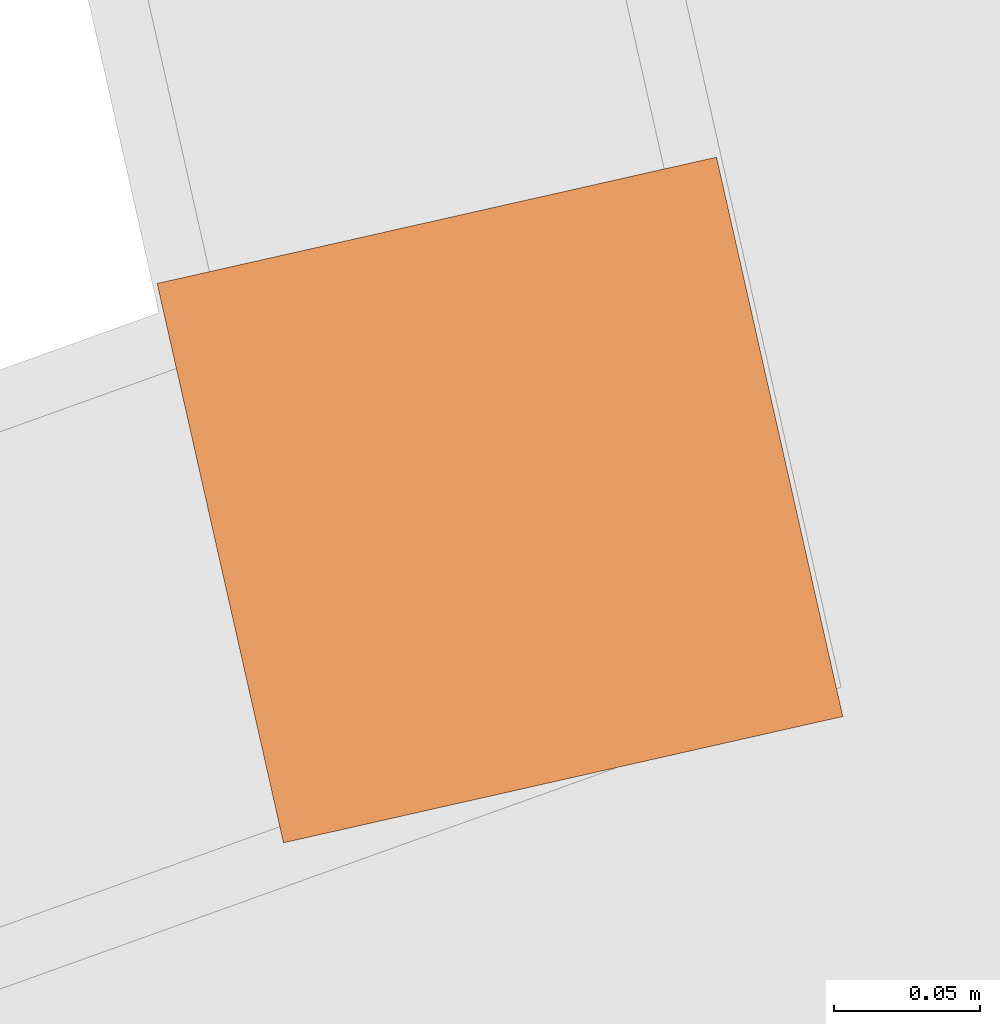
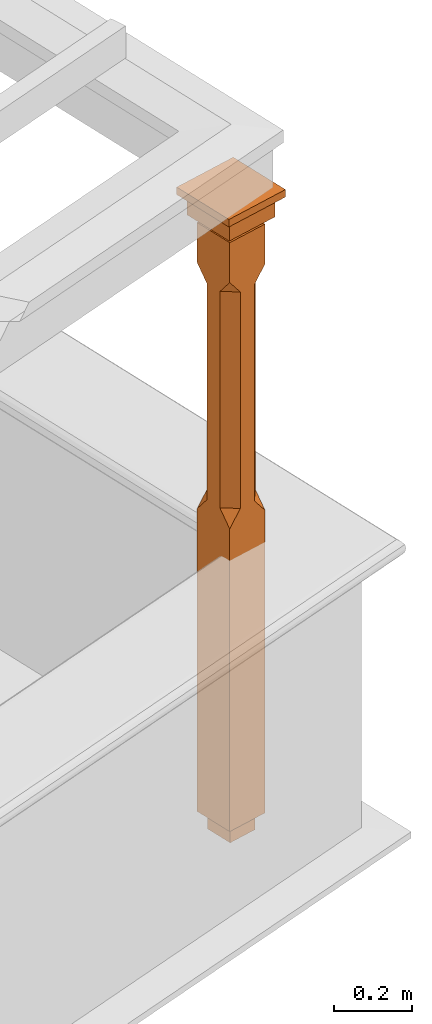
# One storey, part 10 of 10: 1 proxy.
"""IFC2X3 building model written with IfcOpenShell, lengths in metres."""

import ifcopenshell
import ifcopenshell.guid

model = None  # the IFC model being written
_history = None  # IfcOwnerHistory: only IFC2X3 demands one
_inside = {}  # id of a spatial element -> (the spatial element, [elements in it])
_under = {}  # id of a project, library or spatial element -> (it, [spatial elements below it])
_declared = {}  # id of a project -> (the project, [libraries it declares])
_typed = {}  # id of a type object -> (the type object, [elements of that type])
_made_of = {}  # id of a material, layer set ... -> (it, [elements and type objects made of it])


def new_model(schema):
    """Start an empty IFC model of exactly this schema.

    Asked for "IFC4X3", IfcOpenShell would pick the latest addendum, in which some entities
    have other attributes; the version numbers below select the first issue.
    IFC2X3 requires an IfcOwnerHistory on every rooted entity: one is made here for all.
    """
    global model, _history
    if schema == "IFC4X3":
        model = ifcopenshell.file(schema_version=(4, 3, 0, 0))
    else:
        model = ifcopenshell.file(schema=schema)
    _inside.clear()
    _under.clear()
    _declared.clear()
    _typed.clear()
    _made_of.clear()
    _history = None
    if model.schema == "IFC2X3":
        org = make("IfcOrganization", Name="unknown")
        user = make(
            "IfcPersonAndOrganization",
            ThePerson=make("IfcPerson", FamilyName="unknown"),
            TheOrganization=org,
        )
        app = make(
            "IfcApplication",
            ApplicationDeveloper=org,
            Version="unknown",
            ApplicationFullName="unknown",
            ApplicationIdentifier="unknown",
        )
        _history = make(
            "IfcOwnerHistory",
            OwningUser=user,
            OwningApplication=app,
            ChangeAction="ADDED",
            CreationDate=0,
        )
    return model


def make(cls, **values):
    """One entity of the class cls with the attributes given. An attribute that is None is left unset."""
    return model.create_entity(
        cls, **{name: value for name, value in values.items() if value is not None}
    )


def rooted(cls, **values):
    """An entity with a GlobalId (a new one), such as an element, a storey or a relation."""
    return make(cls, GlobalId=ifcopenshell.guid.new(), OwnerHistory=_history, **values)


def si_unit(unit_type, name, prefix=None):
    """IfcSIUnit, for example si_unit("LENGTHUNIT", "METRE", prefix="MILLI")."""
    return make("IfcSIUnit", UnitType=unit_type, Prefix=prefix, Name=name)


def assignment(units):
    """IfcUnitAssignment: the units of a project."""
    return None if units is None else make("IfcUnitAssignment", Units=units)


def point(xyz):
    """IfcCartesianPoint."""
    return None if xyz is None else make("IfcCartesianPoint", Coordinates=xyz)


def direction(xyz):
    """IfcDirection."""
    return None if xyz is None else make("IfcDirection", DirectionRatios=xyz)


def frame(location, z_axis=None, x_axis=None):
    """IfcAxis2Placement3D, a coordinate frame: its origin and axes. An axis left out is left unset."""
    return make(
        "IfcAxis2Placement3D",
        Location=point(location),
        Axis=direction(z_axis),
        RefDirection=direction(x_axis),
    )


def origin():
    """The frame at (0, 0, 0) with its axes left unset."""
    return frame((0.0, 0.0, 0.0))


def place(relative_to, where):
    """IfcLocalPlacement: puts the frame where relative to a parent placement (None: the world)."""
    return make(
        "IfcLocalPlacement", PlacementRelTo=relative_to, RelativePlacement=where
    )


def context(
    kind, dimensions, precision=None, world=None, true_north=None, identifier=None
):
    """IfcGeometricRepresentationContext, for example the 3D "Model" context."""
    return make(
        "IfcGeometricRepresentationContext",
        ContextIdentifier=identifier,
        ContextType=kind,
        CoordinateSpaceDimension=dimensions,
        Precision=precision,
        WorldCoordinateSystem=world,
        TrueNorth=true_north,
    )


def subcontext(parent, identifier, kind, view, scale=None):
    """IfcGeometricRepresentationSubContext, for example "Body" below "Model"."""
    return make(
        "IfcGeometricRepresentationSubContext",
        ContextIdentifier=identifier,
        ContextType=kind,
        ParentContext=parent,
        TargetScale=scale,
        TargetView=view,
    )


def project(units=None, contexts=None):
    """IfcProject with its units and contexts."""
    return rooted(
        "IfcProject",
        Name="project",
        RepresentationContexts=contexts,
        UnitsInContext=assignment(units),
    )


def spatial(cls, under=None, at=None, **own):
    """A site, building, storey or space (cls), placed at a placement, below another one or the project."""
    s = rooted(cls, ObjectPlacement=at, **own)
    if under is not None:
        _under.setdefault(under.id(), (under, []))[1].append(s)
    return s


def faces_of(points, faces, orient=None, outer=None):
    """IfcFace entities. A face is a list of loops; a loop is a list of indices into points, from 0.

    orient and outer hold one flag for each loop. By default every Orientation is true, the
    first loop of a face is its IfcFaceOuterBound and the others are IfcFaceBound.
    """
    made = []
    for i, loops in enumerate(faces):
        bounds = []
        for j, loop in enumerate(loops):
            is_outer = j == 0 if outer is None else outer[i][j]
            bounds.append(
                make(
                    "IfcFaceOuterBound" if is_outer else "IfcFaceBound",
                    Bound=make("IfcPolyLoop", Polygon=[points[k] for k in loop]),
                    Orientation=True if orient is None else orient[i][j],
                )
            )
        made.append(make("IfcFace", Bounds=bounds))
    return made


def faceted_brep(points, faces, orient=None, outer=None, voids=None):
    """IfcFacetedBrep: a solid bounded by flat faces; with voids (closed shells), ...WithVoids."""
    shared = [point(p) for p in points]
    hull = make("IfcClosedShell", CfsFaces=faces_of(shared, faces, orient, outer))
    if voids is None:
        return make("IfcFacetedBrep", Outer=hull)
    return make(
        "IfcFacetedBrepWithVoids",
        Outer=hull,
        Voids=[
            make(cls, CfsFaces=faces_of(shared, fs, o, b)) for cls, fs, o, b in voids
        ],
    )


def shape(context_of_items, identifier, shape_type, items):
    """IfcShapeRepresentation: the items that make up one representation, for example the "Body"."""
    return make(
        "IfcShapeRepresentation",
        ContextOfItems=context_of_items,
        RepresentationIdentifier=identifier,
        RepresentationType=shape_type,
        Items=items,
    )


def made_of(thing, what):
    """Note that an element or type object is made of a material, layer set ...; save() writes the relation."""
    if what is not None:
        _made_of.setdefault(what.id(), (what, []))[1].append(thing)
    return thing


def element(
    cls,
    number,
    at=None,
    inside=None,
    cuts=None,
    type_object=None,
    material=None,
    context=None,
    identifier="Body",
    shape_type=None,
    held_by="IfcProductDefinitionShape",
    body=None,
    shapes=None,
    **own,
):
    """One element of the class cls, such as IfcWall. Its Tag is "e" and its number.

    at: its placement. inside: the storey or other place that contains it. cuts: it is an
    opening in that element (IfcRelVoidsElement). A single representation is given by context,
    identifier, shape_type and body (its items); several are given by shapes. held_by: the class
    of the entity that holds the representations. save() writes the other relations.
    """
    e = rooted(cls, Tag="e%d" % number, ObjectPlacement=at, **own)
    if body is not None:
        shapes = [shape(context, identifier, shape_type, body)]
    if shapes is not None:
        e.Representation = make(held_by, Representations=shapes)
    if inside is not None:
        _inside.setdefault(inside.id(), (inside, []))[1].append(e)
    if cuts is not None:
        rooted(
            "IfcRelVoidsElement", RelatingBuildingElement=cuts, RelatedOpeningElement=e
        )
    if type_object is not None:
        _typed.setdefault(type_object.id(), (type_object, []))[1].append(e)
    return made_of(e, material)


def aggregate(whole, parts):
    """IfcRelAggregates: a whole, such as a stair, and the parts it consists of."""
    return rooted("IfcRelAggregates", RelatingObject=whole, RelatedObjects=parts)


def save(model, path):
    """Write the relations noted so far, then the file.

    IfcRelAggregates (storeys below a building ...), IfcRelContainedInSpatialStructure (elements
    in a storey), IfcRelDefinesByType, IfcRelAssociatesMaterial and IfcRelDeclares: one each for
    every whole, place, type object, material and project.
    """
    for whole, parts in _under.values():
        aggregate(whole, parts)
    for where, things in _inside.values():
        rooted(
            "IfcRelContainedInSpatialStructure",
            RelatedElements=things,
            RelatingStructure=where,
        )
    for kind, things in _typed.values():
        rooted("IfcRelDefinesByType", RelatedObjects=things, RelatingType=kind)
    for what, things in _made_of.values():
        rooted("IfcRelAssociatesMaterial", RelatedObjects=things, RelatingMaterial=what)
    for by, libraries in _declared.values():
        rooted("IfcRelDeclares", RelatingContext=by, RelatedDefinitions=libraries)
    model.write(path)


model = new_model("IFC2X3")

# Units and contexts
model_context = context("Model", 3, world=origin())
body_context = subcontext(model_context, "Body", "Model", "MODEL_VIEW")
ifc_project = project(units=[si_unit("PLANEANGLEUNIT", "RADIAN"), si_unit("MASSUNIT", "GRAM", prefix="KILO"), si_unit("FORCEUNIT", "NEWTON", prefix="KILO"), si_unit("LENGTHUNIT", "METRE")], contexts=[model_context])

# Site, building, storey
site_placement = place(None, origin())
site = spatial("IfcSite", under=ifc_project, at=site_placement, CompositionType="ELEMENT")
building_placement = place(None, origin())
building = spatial("IfcBuilding", under=site, at=building_placement, Name="Building plot-9", CompositionType="ELEMENT")
storey_placement = place(None, frame((0.0, 0.0, 4.3)))
storey = spatial("IfcBuildingStorey", under=building, at=storey_placement, Name="Floor 1", CompositionType="ELEMENT", Elevation=4.3)

# Proxy
proxy_placement = place(storey_placement, frame((41.7519928065851, 17.332454639384, 0.0), z_axis=(0.0, 0.0, 1.0), x_axis=(-0.22030487273232, 0.975431065247768, 0.0)))
element("IfcBuildingElementProxy", 1, at=proxy_placement, inside=storey, Name="pergola post", CompositionType="ELEMENT", context=body_context, shape_type="Brep", held_by="IfcProductRepresentation", body=[
    faceted_brep([(0.0246, -0.0615, 1.72), (0.0615, -0.0246, 1.72), (0.0615, -0.0615, 1.766667), (0.0615, -0.0246, 1.044444), (0.0246, -0.0615, 1.044444), (0.0615, 0.0246, 1.72), (0.0615, 0.0615, 1.766667), (-0.0246, -0.0615, 1.72), (-0.0615, -0.0615, 1.766667), (-0.0246, -0.0615, 1.044444), (0.0615, -0.0615, 0.997778), (0.0615, 0.0246, 1.044444), (0.0246, 0.0615, 1.72), (0.0615, 0.0615, 1.891111), (0.0615, -0.0615, 1.891111), (-0.0615, -0.0615, 1.891111), (-0.0615, -0.0246, 1.72), (-0.0615, -0.0246, 1.044444), (-0.0615, -0.0615, 0.997778), (0.0615, 0.0615, 0.997778), (0.0246, 0.0615, 1.044444), (-0.0246, 0.0615, 1.72), (-0.0615, 0.0615, 1.766667), (0.04305, 0.04305, 1.891111), (0.04305, -0.04305, 1.891111), (-0.0615, 0.0615, 1.891111), (-0.04305, -0.04305, 1.891111), (-0.0615, 0.0246, 1.72), (-0.0615, 0.0246, 1.044444), (0.0615, -0.0615, 0.053333), (-0.0615, -0.0615, 0.053333), (0.0615, 0.0615, 0.053333), (-0.0246, 0.0615, 1.044444), (-0.04305, 0.04305, 1.891111), (0.04305, 0.04305, 1.914444), (0.04305, -0.04305, 1.914444), (-0.04305, -0.04305, 1.914444), (-0.0615, 0.0615, 0.997778), (-0.0615, 0.0615, 0.053333), (-0.04305, -0.04305, 0.053333), (0.04305, -0.04305, 0.053333), (0.04305, 0.04305, 0.053333), (-0.04305, 0.04305, 1.914444), (0.07995, 0.07995, 1.914444), (0.07995, -0.07995, 1.914444), (-0.07995, -0.07995, 1.914444), (-0.04305, 0.04305, 0.053333), (-0.04305, -0.04305, 0.0), (0.04305, -0.04305, 0.0), (0.04305, 0.04305, 0.0), (-0.07995, 0.07995, 1.914444), (0.07995, 0.07995, 1.976667), (0.07995, -0.07995, 1.976667), (-0.07995, -0.07995, 1.976667), (-0.04305, 0.04305, 0.0), (-0.07995, 0.07995, 1.976667), (0.0984, 0.0984, 1.976667), (0.0984, -0.0984, 1.976667), (-0.0984, -0.0984, 1.976667), (-0.0984, 0.0984, 1.976667), (0.0984, 0.0984, 2.0), (0.0984, -0.0984, 2.0), (-0.0984, -0.0984, 2.0), (-0.0984, 0.0984, 2.0)], [[[0, 1, 2]], [[3, 1, 0, 4]], [[1, 5, 6, 2]], [[7, 0, 2, 8]], [[4, 0, 7, 9]], [[3, 4, 10]], [[1, 3, 11, 5]], [[5, 12, 6]], [[13, 14, 2, 6]], [[15, 8, 2, 14]], [[8, 16, 7]], [[9, 7, 16, 17]], [[9, 18, 10, 4]], [[3, 10, 19, 11]], [[20, 12, 5, 11]], [[21, 22, 6, 12]], [[14, 13, 23, 24]], [[13, 6, 22, 25]], [[25, 22, 8, 15]], [[26, 15, 14, 24]], [[16, 8, 22, 27]], [[27, 28, 17, 16]], [[17, 18, 9]], [[29, 10, 18, 30]], [[31, 19, 10, 29]], [[20, 11, 19]], [[12, 20, 32, 21]], [[21, 27, 22]], [[33, 23, 13, 25]], [[23, 34, 35, 24]], [[26, 33, 25, 15]], [[36, 26, 24, 35]], [[28, 27, 21, 32]], [[17, 28, 37, 18]], [[38, 30, 18, 37]], [[29, 30, 39, 40]], [[31, 38, 37, 19]], [[40, 41, 31, 29]], [[32, 20, 19, 37]], [[33, 42, 34, 23]], [[43, 44, 35, 34]], [[42, 33, 26, 36]], [[36, 35, 44, 45]], [[28, 32, 37]], [[46, 39, 30, 38]], [[39, 47, 48, 40]], [[46, 38, 31, 41]], [[49, 41, 40, 48]], [[43, 34, 42, 50]], [[43, 51, 52, 44]], [[45, 50, 42, 36]], [[53, 45, 44, 52]], [[46, 54, 47, 39]], [[54, 46, 41, 49]], [[50, 55, 51, 43]], [[56, 57, 52, 51]], [[55, 50, 45, 53]], [[53, 52, 57, 58]], [[56, 51, 55, 59]], [[56, 60, 61, 57]], [[58, 59, 55, 53]], [[62, 58, 57, 61]], [[59, 63, 60, 56]], [[63, 62, 61, 60]], [[58, 62, 63, 59]], [[47, 54, 49, 48]]]),
])

save(model, "model.ifc")
